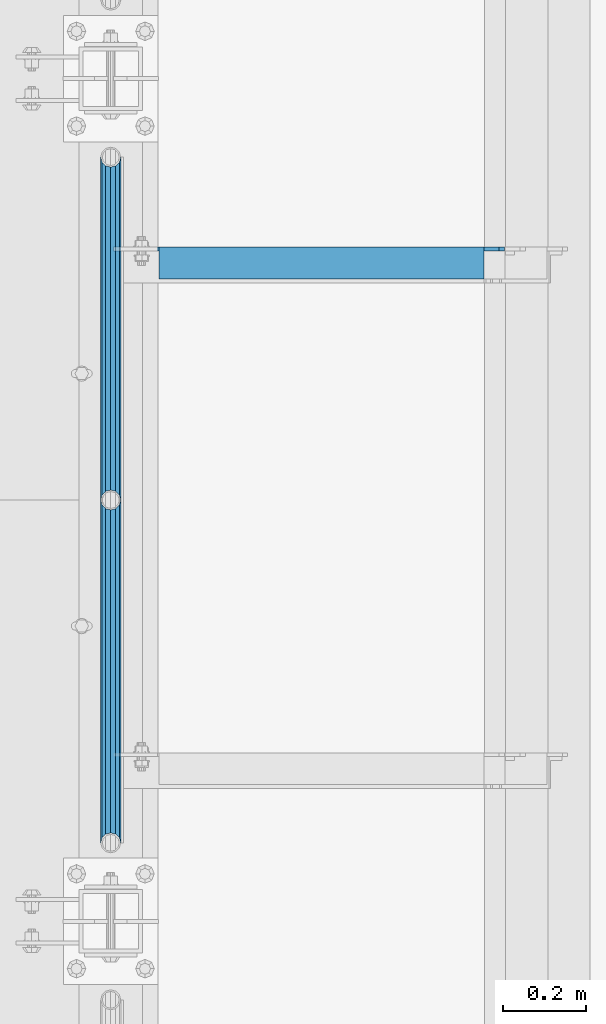
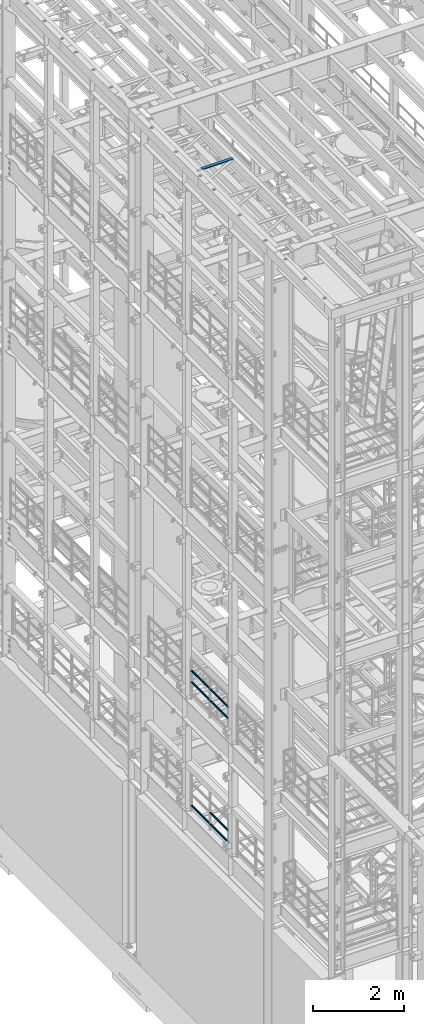
# One storey, part 1228 of 1876: 8 beams, 3 elements without a shape of their own.
"""IFC2X3 building model written with IfcOpenShell, lengths in millimetres."""

from ifc_helpers import new_model, si_unit, frame, origin_with_axes, place, context, subcontext, project, spatial, faceted_brep, material, type_object, element, aggregate, save


model = new_model("IFC2X3")

# Units and contexts
model_context = context("Model", 3, precision=1e-05, world=origin_with_axes())
body_context = subcontext(model_context, "Body", "Model", "MODEL_VIEW")
ifc_project = project(units=[si_unit("LENGTHUNIT", "METRE", prefix="MILLI"), si_unit("AREAUNIT", "SQUARE_METRE"), si_unit("VOLUMEUNIT", "CUBIC_METRE"), si_unit("MASSUNIT", "GRAM", prefix="KILO"), si_unit("TIMEUNIT", "SECOND"), si_unit("PLANEANGLEUNIT", "RADIAN"), si_unit("SOLIDANGLEUNIT", "STERADIAN"), si_unit("THERMODYNAMICTEMPERATUREUNIT", "DEGREE_CELSIUS"), si_unit("LUMINOUSINTENSITYUNIT", "LUMEN")], contexts=[model_context])

# Site, building, storey
site_placement = place(None, origin_with_axes())
site = spatial("IfcSite", under=ifc_project, at=site_placement, CompositionType="ELEMENT")
building_placement = place(site_placement, origin_with_axes())
building = spatial("IfcBuilding", under=site, at=building_placement, Name="Undefined", CompositionType="ELEMENT")
storey_placement = place(building_placement, origin_with_axes())
storey = spatial("IfcBuildingStorey", under=building, at=storey_placement, Name="Undefined", CompositionType="ELEMENT", Elevation=0.0)

# Assembly, beams
assembly_1_placement = place(storey_placement, origin_with_axes())
assembly_1 = element("IfcElementAssembly", 1, at=assembly_1_placement, inside=storey, Name="RAIL", AssemblyPlace="NOTDEFINED", PredefinedType="RIGID_FRAME")
ifc_material_1 = material()
beam_type_1 = type_object("IfcBeamType", Name="PIPE1-1/2SCH40", PredefinedType="NOTDEFINED")
beam_1_placement = place(assembly_1_placement, frame((-1.81898940354586e-12, -2350.77, 8620.125), z_axis=(0.0, 0.0, -1.0), x_axis=(0.0, 1.0, 0.0)))
beam_1 = element("IfcBeam", 2, at=beam_1_placement, type_object=beam_type_1, material=ifc_material_1, Name="RAIL", ObjectType="PIPE1-1/2SCH40", context=body_context, shape_type="Brep", body=[
    faceted_brep([(0.0, 24.1299999999992, 0.0), (12.0650000000064, 20.8971929933177, -12.0649999999987), (12.0650000000064, 20.8971929933177, 12.0649999999987), (12.0650000000064, -20.8971929933177, 12.0649999999987), (12.0650000000064, -20.8971929933177, -12.0649999999987), (0.0, -24.1299999999992, 0.0), (20.8971929933249, -12.0650000000005, 20.8971929933177), (20.8971929933249, -12.0650000000005, 15.8661214311796), (15.2545715621445, -17.7076214311801, 10.2235000000001), (12.5151929933249, -20.4470000000001, 0.0), (15.2545715621445, -17.7076214311801, -10.2235000000001), (20.8971929933249, -12.0650000000005, -15.8661214311796), (20.8971929933249, -12.0650000000005, -20.8971929933177), (24.1300000000063, 0.0, -20.4470000000001), (24.1300000000063, 0.0, -24.130000000001), (21.3906214311868, -10.2235000000001, -17.7076214311819), (21.3906214311868, 10.2235000000001, -17.7076214311819), (20.8971929933249, 12.0650000000005, -15.8661214311796), (20.8971929933249, 12.0650000000005, -20.8971929933177), (15.2545715621445, 17.7076214311801, -10.2235000000001), (12.5151929933249, 20.4470000000001, 0.0), (15.2545715621445, 17.7076214311801, 10.2235000000001), (20.8971929933249, 12.0650000000005, 15.8661214311796), (20.8971929933249, 12.0650000000005, 20.8971929933177), (21.3906214311868, 10.2235000000001, 17.7076214311819), (24.1300000000064, 0.0, 20.4470000000001), (24.1300000000064, 0.0, 24.130000000001), (21.3906214311868, -10.2235000000001, 17.7076214311819), (826.77, 24.1300000000001, 0.0), (814.705, 20.8971929933186, -12.0649999999987), (805.872807006681, 12.0649999999996, -20.8971929933177), (826.77, -24.1300000000001, 0.0), (814.705, -20.8971929933186, -12.0649999999987), (814.705, -20.8971929933186, 12.0649999999987), (805.872807006681, -12.0649999999996, 20.8971929933177), (805.872807006681, -12.0649999999996, -20.8971929933177), (802.640000000001, 0.0, -24.130000000001), (805.379378568819, 10.2235000000001, -17.7076214311819), (802.640000000001, 0.0, -20.4470000000001), (805.872807006683, 12.0649999999996, -15.8661214311796), (805.872807006683, -12.0649999999996, -15.8661214311796), (805.379378568819, -10.2235000000001, -17.7076214311819), (811.515428437862, -17.7076214311801, -10.2235000000001), (814.254807006682, -20.4470000000001, 0.0), (811.515428437862, -17.7076214311801, 10.2235000000001), (805.872807006683, -12.0649999999996, 15.8661214311796), (805.379378568819, -10.2235000000001, 17.7076214311819), (802.640000000001, 0.0, 20.4470000000001), (802.640000000001, 0.0, 24.130000000001), (805.872807006681, 12.0649999999996, 20.8971929933177), (814.705, 20.8971929933186, 12.0649999999987), (805.872807006683, 12.0649999999996, 15.8661214311796), (811.515428437862, 17.7076214311801, 10.2235000000001), (814.254807006682, 20.4470000000001, 0.0), (811.515428437862, 17.7076214311801, -10.2235000000001), (805.379378568819, 10.2235000000001, 17.7076214311819)], [[[0, 1, 2]], [[3, 4, 5]], [[6, 7, 8, 9, 10, 11, 12, 4, 3]], [[13, 14, 12, 11, 15]], [[16, 17, 18, 14, 13]], [[2, 1, 18, 17, 19, 20, 21, 22, 23]], [[23, 22, 24, 25, 26]], [[26, 25, 27, 7, 6]], [[1, 0, 28, 29]], [[18, 1, 29, 30]], [[31, 32, 33]], [[6, 3, 33, 34]], [[3, 5, 31, 33]], [[5, 4, 32, 31]], [[4, 12, 35, 32]], [[12, 14, 36, 35]], [[14, 18, 30, 36]], [[37, 38, 36, 30, 39]], [[40, 35, 36, 38, 41]], [[33, 32, 35, 40, 42, 43, 44, 45, 34]], [[34, 45, 46, 47, 48]], [[26, 6, 34, 48]], [[2, 23, 49, 50]], [[23, 26, 48, 49]], [[0, 2, 50, 28]], [[28, 50, 29]], [[49, 51, 52, 53, 54, 39, 30, 29, 50]], [[48, 47, 55, 51, 49]], [[25, 24, 55, 47]], [[55, 24, 22, 21, 52, 51]], [[21, 20, 53, 52]], [[20, 19, 54, 53]], [[19, 17, 16, 37, 39, 54]], [[16, 13, 38, 37]], [[13, 15, 41, 38]], [[41, 15, 11, 10, 42, 40]], [[10, 9, 43, 42]], [[9, 8, 44, 43]], [[8, 7, 27, 46, 45, 44]], [[27, 25, 47, 46]]]),
])
beam_2_placement = place(assembly_1_placement, frame((-1.81898940354586e-12, -1524.0, 8620.125), z_axis=(0.0, 0.0, -1.0), x_axis=(0.0, 1.0, 0.0)))
beam_2 = element("IfcBeam", 3, at=beam_2_placement, type_object=beam_type_1, material=ifc_material_1, Name="RAIL", ObjectType="PIPE1-1/2SCH40", context=body_context, shape_type="Brep", body=[
    faceted_brep([(0.0, 24.1299999999992, 0.0), (12.0650000000064, 20.8971929933177, -12.0649999999987), (12.0650000000064, 20.8971929933177, 12.0649999999987), (12.0650000000064, -20.8971929933177, 12.0649999999987), (12.0650000000064, -20.8971929933177, -12.0649999999987), (0.0, -24.1299999999992, 0.0), (20.8971929933249, -12.0650000000005, 20.8971929933177), (20.8971929933249, -12.0650000000005, 15.8661214311796), (15.2545715621445, -17.7076214311801, 10.2235000000001), (12.5151929933249, -20.4470000000001, 0.0), (15.2545715621445, -17.7076214311801, -10.2235000000001), (20.8971929933249, -12.0650000000005, -15.8661214311796), (20.8971929933249, -12.0650000000005, -20.8971929933177), (24.1300000000063, 0.0, -20.4470000000001), (24.1300000000063, 0.0, -24.130000000001), (21.3906214311868, -10.2235000000001, -17.7076214311819), (21.3906214311868, 10.2235000000001, -17.7076214311819), (20.8971929933249, 12.0650000000005, -15.8661214311796), (20.8971929933249, 12.0650000000005, -20.8971929933177), (15.2545715621445, 17.7076214311801, -10.2235000000001), (12.5151929933249, 20.4470000000001, 0.0), (15.2545715621445, 17.7076214311801, 10.2235000000001), (20.8971929933249, 12.0650000000005, 15.8661214311796), (20.8971929933249, 12.0650000000005, 20.8971929933177), (21.3906214311868, 10.2235000000001, 17.7076214311819), (24.1300000000064, 0.0, 20.4470000000001), (24.1300000000064, 0.0, 24.130000000001), (21.3906214311868, -10.2235000000001, 17.7076214311819), (826.77, 24.1300000000001, 0.0), (814.705, 20.8971929933186, -12.0649999999987), (805.872807006681, 12.0649999999996, -20.8971929933177), (826.77, -24.1300000000001, 0.0), (814.705, -20.8971929933186, -12.0649999999987), (814.705, -20.8971929933186, 12.0649999999987), (805.872807006681, -12.0649999999996, 20.8971929933177), (805.872807006681, -12.0649999999996, -20.8971929933177), (802.640000000001, 0.0, -24.130000000001), (805.379378568819, 10.2235000000001, -17.7076214311819), (802.640000000001, 0.0, -20.4470000000001), (805.872807006683, 12.0649999999996, -15.8661214311796), (805.872807006683, -12.0649999999996, -15.8661214311796), (805.379378568819, -10.2235000000001, -17.7076214311819), (811.515428437862, -17.7076214311801, -10.2235000000001), (814.254807006682, -20.4470000000001, 0.0), (811.515428437862, -17.7076214311801, 10.2235000000001), (805.872807006683, -12.0649999999996, 15.8661214311796), (805.379378568819, -10.2235000000001, 17.7076214311819), (802.640000000001, 0.0, 20.4470000000001), (802.640000000001, 0.0, 24.130000000001), (805.872807006681, 12.0649999999996, 20.8971929933177), (814.705, 20.8971929933186, 12.0649999999987), (805.872807006683, 12.0649999999996, 15.8661214311796), (811.515428437862, 17.7076214311801, 10.2235000000001), (814.254807006682, 20.4470000000001, 0.0), (811.515428437862, 17.7076214311801, -10.2235000000001), (805.379378568819, 10.2235000000001, 17.7076214311819)], [[[0, 1, 2]], [[3, 4, 5]], [[6, 7, 8, 9, 10, 11, 12, 4, 3]], [[13, 14, 12, 11, 15]], [[16, 17, 18, 14, 13]], [[2, 1, 18, 17, 19, 20, 21, 22, 23]], [[23, 22, 24, 25, 26]], [[26, 25, 27, 7, 6]], [[1, 0, 28, 29]], [[18, 1, 29, 30]], [[31, 32, 33]], [[6, 3, 33, 34]], [[3, 5, 31, 33]], [[5, 4, 32, 31]], [[4, 12, 35, 32]], [[12, 14, 36, 35]], [[14, 18, 30, 36]], [[37, 38, 36, 30, 39]], [[40, 35, 36, 38, 41]], [[33, 32, 35, 40, 42, 43, 44, 45, 34]], [[34, 45, 46, 47, 48]], [[26, 6, 34, 48]], [[2, 23, 49, 50]], [[23, 26, 48, 49]], [[0, 2, 50, 28]], [[28, 50, 29]], [[49, 51, 52, 53, 54, 39, 30, 29, 50]], [[48, 47, 55, 51, 49]], [[25, 24, 55, 47]], [[55, 24, 22, 21, 52, 51]], [[21, 20, 53, 52]], [[20, 19, 54, 53]], [[19, 17, 16, 37, 39, 54]], [[16, 13, 38, 37]], [[13, 15, 41, 38]], [[41, 15, 11, 10, 42, 40]], [[10, 9, 43, 42]], [[9, 8, 44, 43]], [[8, 7, 27, 46, 45, 44]], [[27, 25, 47, 46]]]),
])
beam_3_placement = place(assembly_1_placement, frame((-1.81898940354586e-12, -2350.77, 8924.925), z_axis=(0.0, 0.0, -1.0), x_axis=(0.0, 1.0, 0.0)))
beam_3 = element("IfcBeam", 4, at=beam_3_placement, type_object=beam_type_1, material=ifc_material_1, Name="RAIL", ObjectType="PIPE1-1/2SCH40", context=body_context, shape_type="Brep", body=[
    faceted_brep([(0.0, 24.1299999999992, 0.0), (12.0650000000064, 20.8971929933177, -12.0649999999987), (12.0650000000064, 20.8971929933177, 12.0649999999987), (12.0650000000064, -20.8971929933177, 12.0649999999987), (12.0650000000064, -20.8971929933177, -12.0649999999987), (0.0, -24.1299999999992, 0.0), (20.8971929933249, -12.0650000000005, 20.8971929933177), (20.8971929933249, -12.0650000000005, 15.8661214311796), (15.2545715621445, -17.7076214311801, 10.2235000000001), (12.5151929933249, -20.4470000000001, 0.0), (15.2545715621445, -17.7076214311801, -10.2235000000001), (20.8971929933249, -12.0650000000005, -15.8661214311796), (20.8971929933249, -12.0650000000005, -20.8971929933177), (24.1300000000063, 0.0, -20.4470000000001), (24.1300000000063, 0.0, -24.130000000001), (21.3906214311868, -10.2235000000001, -17.7076214311819), (21.3906214311868, 10.2235000000001, -17.7076214311819), (20.8971929933249, 12.0650000000005, -15.8661214311796), (20.8971929933249, 12.0650000000005, -20.8971929933177), (15.2545715621445, 17.7076214311801, -10.2235000000001), (12.5151929933249, 20.4470000000001, 0.0), (15.2545715621445, 17.7076214311801, 10.2235000000001), (20.8971929933249, 12.0650000000005, 15.8661214311796), (20.8971929933249, 12.0650000000005, 20.8971929933177), (21.3906214311868, 10.2235000000001, 17.7076214311819), (24.1300000000064, 0.0, 20.4470000000001), (24.1300000000064, 0.0, 24.130000000001), (21.3906214311868, -10.2235000000001, 17.7076214311819), (826.77, 24.1300000000001, 0.0), (814.705, 20.8971929933186, -12.0649999999987), (805.872807006681, 12.0649999999996, -20.8971929933177), (826.77, -24.1300000000001, 0.0), (814.705, -20.8971929933186, -12.0649999999987), (814.705, -20.8971929933186, 12.0649999999987), (805.872807006681, -12.0649999999996, 20.8971929933177), (805.872807006681, -12.0649999999996, -20.8971929933177), (802.640000000001, 0.0, -24.130000000001), (805.379378568819, 10.2235000000001, -17.7076214311819), (802.640000000001, 0.0, -20.4470000000001), (805.872807006683, 12.0649999999996, -15.8661214311796), (805.872807006683, -12.0649999999996, -15.8661214311796), (805.379378568819, -10.2235000000001, -17.7076214311819), (811.515428437862, -17.7076214311801, -10.2235000000001), (814.254807006682, -20.4470000000001, 0.0), (811.515428437862, -17.7076214311801, 10.2235000000001), (805.872807006683, -12.0649999999996, 15.8661214311796), (805.379378568819, -10.2235000000001, 17.7076214311819), (802.640000000001, 0.0, 20.4470000000001), (802.640000000001, 0.0, 24.130000000001), (805.872807006681, 12.0649999999996, 20.8971929933177), (814.705, 20.8971929933186, 12.0649999999987), (805.872807006683, 12.0649999999996, 15.8661214311796), (811.515428437862, 17.7076214311801, 10.2235000000001), (814.254807006682, 20.4470000000001, 0.0), (811.515428437862, 17.7076214311801, -10.2235000000001), (805.379378568819, 10.2235000000001, 17.7076214311819)], [[[0, 1, 2]], [[3, 4, 5]], [[6, 7, 8, 9, 10, 11, 12, 4, 3]], [[13, 14, 12, 11, 15]], [[16, 17, 18, 14, 13]], [[2, 1, 18, 17, 19, 20, 21, 22, 23]], [[23, 22, 24, 25, 26]], [[26, 25, 27, 7, 6]], [[1, 0, 28, 29]], [[18, 1, 29, 30]], [[31, 32, 33]], [[6, 3, 33, 34]], [[3, 5, 31, 33]], [[5, 4, 32, 31]], [[4, 12, 35, 32]], [[12, 14, 36, 35]], [[14, 18, 30, 36]], [[37, 38, 36, 30, 39]], [[40, 35, 36, 38, 41]], [[33, 32, 35, 40, 42, 43, 44, 45, 34]], [[34, 45, 46, 47, 48]], [[26, 6, 34, 48]], [[2, 23, 49, 50]], [[23, 26, 48, 49]], [[0, 2, 50, 28]], [[28, 50, 29]], [[49, 51, 52, 53, 54, 39, 30, 29, 50]], [[48, 47, 55, 51, 49]], [[25, 24, 55, 47]], [[55, 24, 22, 21, 52, 51]], [[21, 20, 53, 52]], [[20, 19, 54, 53]], [[19, 17, 16, 37, 39, 54]], [[16, 13, 38, 37]], [[13, 15, 41, 38]], [[41, 15, 11, 10, 42, 40]], [[10, 9, 43, 42]], [[9, 8, 44, 43]], [[8, 7, 27, 46, 45, 44]], [[27, 25, 47, 46]]]),
])
beam_4_placement = place(assembly_1_placement, frame((-1.81898940354586e-12, -1524.0, 8924.925), z_axis=(0.0, 0.0, -1.0), x_axis=(0.0, 1.0, 0.0)))
beam_4 = element("IfcBeam", 5, at=beam_4_placement, type_object=beam_type_1, material=ifc_material_1, Name="RAIL", ObjectType="PIPE1-1/2SCH40", context=body_context, shape_type="Brep", body=[
    faceted_brep([(0.0, 24.1299999999992, 0.0), (12.0650000000064, 20.8971929933177, -12.0649999999987), (12.0650000000064, 20.8971929933177, 12.0649999999987), (12.0650000000064, -20.8971929933177, 12.0649999999987), (12.0650000000064, -20.8971929933177, -12.0649999999987), (0.0, -24.1299999999992, 0.0), (20.8971929933249, -12.0650000000005, 20.8971929933177), (20.8971929933249, -12.0650000000005, 15.8661214311796), (15.2545715621445, -17.7076214311801, 10.2235000000001), (12.5151929933249, -20.4470000000001, 0.0), (15.2545715621445, -17.7076214311801, -10.2235000000001), (20.8971929933249, -12.0650000000005, -15.8661214311796), (20.8971929933249, -12.0650000000005, -20.8971929933177), (24.1300000000063, 0.0, -20.4470000000001), (24.1300000000063, 0.0, -24.130000000001), (21.3906214311868, -10.2235000000001, -17.7076214311819), (21.3906214311868, 10.2235000000001, -17.7076214311819), (20.8971929933249, 12.0650000000005, -15.8661214311796), (20.8971929933249, 12.0650000000005, -20.8971929933177), (15.2545715621445, 17.7076214311801, -10.2235000000001), (12.5151929933249, 20.4470000000001, 0.0), (15.2545715621445, 17.7076214311801, 10.2235000000001), (20.8971929933249, 12.0650000000005, 15.8661214311796), (20.8971929933249, 12.0650000000005, 20.8971929933177), (21.3906214311868, 10.2235000000001, 17.7076214311819), (24.1300000000064, 0.0, 20.4470000000001), (24.1300000000064, 0.0, 24.130000000001), (21.3906214311868, -10.2235000000001, 17.7076214311819), (826.77, 24.1300000000001, 0.0), (814.705, 20.8971929933186, -12.0649999999987), (805.872807006681, 12.0649999999996, -20.8971929933177), (826.77, -24.1300000000001, 0.0), (814.705, -20.8971929933186, -12.0649999999987), (814.705, -20.8971929933186, 12.0649999999987), (805.872807006681, -12.0649999999996, 20.8971929933177), (805.872807006681, -12.0649999999996, -20.8971929933177), (802.640000000001, 0.0, -24.130000000001), (805.379378568819, 10.2235000000001, -17.7076214311819), (802.640000000001, 0.0, -20.4470000000001), (805.872807006683, 12.0649999999996, -15.8661214311796), (805.872807006683, -12.0649999999996, -15.8661214311796), (805.379378568819, -10.2235000000001, -17.7076214311819), (811.515428437862, -17.7076214311801, -10.2235000000001), (814.254807006682, -20.4470000000001, 0.0), (811.515428437862, -17.7076214311801, 10.2235000000001), (805.872807006683, -12.0649999999996, 15.8661214311796), (805.379378568819, -10.2235000000001, 17.7076214311819), (802.640000000001, 0.0, 20.4470000000001), (802.640000000001, 0.0, 24.130000000001), (805.872807006681, 12.0649999999996, 20.8971929933177), (814.705, 20.8971929933186, 12.0649999999987), (805.872807006683, 12.0649999999996, 15.8661214311796), (811.515428437862, 17.7076214311801, 10.2235000000001), (814.254807006682, 20.4470000000001, 0.0), (811.515428437862, 17.7076214311801, -10.2235000000001), (805.379378568819, 10.2235000000001, 17.7076214311819)], [[[0, 1, 2]], [[3, 4, 5]], [[6, 7, 8, 9, 10, 11, 12, 4, 3]], [[13, 14, 12, 11, 15]], [[16, 17, 18, 14, 13]], [[2, 1, 18, 17, 19, 20, 21, 22, 23]], [[23, 22, 24, 25, 26]], [[26, 25, 27, 7, 6]], [[1, 0, 28, 29]], [[18, 1, 29, 30]], [[31, 32, 33]], [[6, 3, 33, 34]], [[3, 5, 31, 33]], [[5, 4, 32, 31]], [[4, 12, 35, 32]], [[12, 14, 36, 35]], [[14, 18, 30, 36]], [[37, 38, 36, 30, 39]], [[40, 35, 36, 38, 41]], [[33, 32, 35, 40, 42, 43, 44, 45, 34]], [[34, 45, 46, 47, 48]], [[26, 6, 34, 48]], [[2, 23, 49, 50]], [[23, 26, 48, 49]], [[0, 2, 50, 28]], [[28, 50, 29]], [[49, 51, 52, 53, 54, 39, 30, 29, 50]], [[48, 47, 55, 51, 49]], [[25, 24, 55, 47]], [[55, 24, 22, 21, 52, 51]], [[21, 20, 53, 52]], [[20, 19, 54, 53]], [[19, 17, 16, 37, 39, 54]], [[16, 13, 38, 37]], [[13, 15, 41, 38]], [[41, 15, 11, 10, 42, 40]], [[10, 9, 43, 42]], [[9, 8, 44, 43]], [[8, 7, 27, 46, 45, 44]], [[27, 25, 47, 46]]]),
])
aggregate(assembly_1, [beam_1, beam_2, beam_3, beam_4])

assembly_2_placement = place(storey_placement, origin_with_axes())
assembly_2 = element("IfcElementAssembly", 6, at=assembly_2_placement, inside=storey, Name="RAIL", AssemblyPlace="NOTDEFINED", PredefinedType="RIGID_FRAME")
beam_5_placement = place(assembly_2_placement, frame((-1.81898940354586e-12, -1524.0, 5292.725), z_axis=(0.0, 0.0, 1.0), x_axis=(0.0, -1.0, 0.0)))
beam_5 = element("IfcBeam", 7, at=beam_5_placement, type_object=beam_type_1, material=ifc_material_1, Name="RAIL", ObjectType="PIPE1-1/2SCH40", context=body_context, shape_type="Brep", body=[
    faceted_brep([(805.872807006681, -12.0649999999996, 20.8971929933177), (805.872807006683, -12.0649999999996, 15.8661214311796), (805.379378568819, -10.2235000000001, 17.7076214311819), (802.640000000001, 0.0, 20.4470000000001), (802.640000000001, 0.0, 24.130000000001), (805.379378568819, 10.2235000000001, 17.7076214311819), (805.872807006683, 12.0649999999996, 15.8661214311796), (805.872807006681, 12.0649999999996, 20.8971929933177), (826.77, 24.1300000000001, 0.0), (814.705, 20.8971929933186, 12.0649999999987), (814.705, 20.8971929933186, -12.0649999999987), (811.515428437862, 17.7076214311801, 10.2235000000001), (814.254807006682, 20.4470000000001, 0.0), (811.515428437862, 17.7076214311801, -10.2235000000001), (805.872807006683, 12.0649999999996, -15.8661214311796), (805.872807006681, 12.0649999999996, -20.8971929933177), (805.379378568819, 10.2235000000001, -17.7076214311819), (802.640000000001, 0.0, -20.4470000000001), (802.640000000001, 0.0, -24.130000000001), (805.872807006683, -12.0649999999996, -15.8661214311796), (805.872807006681, -12.0649999999996, -20.8971929933177), (805.379378568819, -10.2235000000001, -17.7076214311819), (826.77, -24.1300000000001, 0.0), (814.705, -20.8971929933186, -12.0649999999987), (814.705, -20.8971929933186, 12.0649999999987), (811.515428437862, -17.7076214311801, -10.2235000000001), (814.254807006682, -20.4470000000001, 0.0), (811.515428437862, -17.7076214311801, 10.2235000000001), (12.0650000000064, -20.8971929933177, -12.0649999999987), (20.8971929933249, -12.0650000000005, -20.8971929933177), (0.0, 24.1299999999992, 0.0), (12.0650000000064, 20.8971929933177, -12.0649999999987), (12.0650000000064, 20.8971929933177, 12.0649999999987), (20.8971929933249, 12.0650000000005, 20.8971929933177), (24.1300000000064, 0.0, 24.130000000001), (20.8971929933249, 12.0650000000005, -20.8971929933177), (24.1300000000063, 0.0, -24.130000000001), (24.1300000000063, 0.0, -20.4470000000001), (20.8971929933249, -12.0650000000005, -15.8661214311796), (21.3906214311868, -10.2235000000001, -17.7076214311819), (21.3906214311868, 10.2235000000001, -17.7076214311819), (20.8971929933249, 12.0650000000005, -15.8661214311796), (15.2545715621445, 17.7076214311801, -10.2235000000001), (12.5151929933249, 20.4470000000001, 0.0), (15.2545715621445, 17.7076214311801, 10.2235000000001), (20.8971929933249, 12.0650000000005, 15.8661214311796), (21.3906214311868, 10.2235000000001, 17.7076214311819), (24.1300000000064, 0.0, 20.4470000000001), (21.3906214311868, -10.2235000000001, 17.7076214311819), (20.8971929933249, -12.0650000000005, 15.8661214311796), (20.8971929933249, -12.0650000000005, 20.8971929933177), (12.0650000000064, -20.8971929933177, 12.0649999999987), (0.0, -24.1299999999992, 0.0), (15.2545715621445, -17.7076214311801, 10.2235000000001), (12.5151929933249, -20.4470000000001, 0.0), (15.2545715621445, -17.7076214311801, -10.2235000000001)], [[[0, 1, 2, 3, 4]], [[4, 3, 5, 6, 7]], [[8, 9, 10]], [[7, 6, 11, 12, 13, 14, 15, 10, 9]], [[16, 17, 18, 15, 14]], [[19, 20, 18, 17, 21]], [[22, 23, 24]], [[24, 23, 20, 19, 25, 26, 27, 1, 0]], [[28, 29, 20, 23]], [[30, 31, 32]], [[33, 34, 4, 7]], [[32, 33, 7, 9]], [[30, 32, 9, 8]], [[31, 30, 8, 10]], [[35, 31, 10, 15]], [[36, 35, 15, 18]], [[29, 36, 18, 20]], [[37, 36, 29, 38, 39]], [[40, 41, 35, 36, 37]], [[32, 31, 35, 41, 42, 43, 44, 45, 33]], [[33, 45, 46, 47, 34]], [[34, 47, 48, 49, 50]], [[34, 50, 0, 4]], [[50, 51, 24, 0]], [[51, 52, 22, 24]], [[52, 28, 23, 22]], [[51, 28, 52]], [[50, 49, 53, 54, 55, 38, 29, 28, 51]], [[55, 54, 26, 25]], [[21, 39, 38, 55, 25, 19]], [[37, 39, 21, 17]], [[40, 37, 17, 16]], [[42, 41, 40, 16, 14, 13]], [[43, 42, 13, 12]], [[44, 43, 12, 11]], [[5, 46, 45, 44, 11, 6]], [[47, 46, 5, 3]], [[48, 47, 3, 2]], [[53, 49, 48, 2, 1, 27]], [[54, 53, 27, 26]]]),
])
beam_6_placement = place(assembly_2_placement, frame((-1.81898940354586e-12, -697.230000000001, 5292.725), z_axis=(0.0, 0.0, 1.0), x_axis=(0.0, -1.0, 0.0)))
beam_6 = element("IfcBeam", 8, at=beam_6_placement, type_object=beam_type_1, material=ifc_material_1, Name="RAIL", ObjectType="PIPE1-1/2SCH40", context=body_context, shape_type="Brep", body=[
    faceted_brep([(805.872807006681, -12.0649999999996, 20.8971929933177), (805.872807006683, -12.0649999999996, 15.8661214311796), (805.379378568819, -10.2235000000001, 17.7076214311819), (802.640000000001, 0.0, 20.4470000000001), (802.640000000001, 0.0, 24.130000000001), (805.379378568819, 10.2235000000001, 17.7076214311819), (805.872807006683, 12.0649999999996, 15.8661214311796), (805.872807006681, 12.0649999999996, 20.8971929933177), (826.77, 24.1300000000001, 0.0), (814.705, 20.8971929933186, 12.0649999999987), (814.705, 20.8971929933186, -12.0649999999987), (811.515428437862, 17.7076214311801, 10.2235000000001), (814.254807006682, 20.4470000000001, 0.0), (811.515428437862, 17.7076214311801, -10.2235000000001), (805.872807006683, 12.0649999999996, -15.8661214311796), (805.872807006681, 12.0649999999996, -20.8971929933177), (805.379378568819, 10.2235000000001, -17.7076214311819), (802.640000000001, 0.0, -20.4470000000001), (802.640000000001, 0.0, -24.130000000001), (805.872807006683, -12.0649999999996, -15.8661214311796), (805.872807006681, -12.0649999999996, -20.8971929933177), (805.379378568819, -10.2235000000001, -17.7076214311819), (826.77, -24.1300000000001, 0.0), (814.705, -20.8971929933186, -12.0649999999987), (814.705, -20.8971929933186, 12.0649999999987), (811.515428437862, -17.7076214311801, -10.2235000000001), (814.254807006682, -20.4470000000001, 0.0), (811.515428437862, -17.7076214311801, 10.2235000000001), (12.0650000000064, -20.8971929933177, -12.0649999999987), (20.8971929933249, -12.0650000000005, -20.8971929933177), (0.0, 24.1299999999992, 0.0), (12.0650000000064, 20.8971929933177, -12.0649999999987), (12.0650000000064, 20.8971929933177, 12.0649999999987), (20.8971929933249, 12.0650000000005, 20.8971929933177), (24.1300000000064, 0.0, 24.130000000001), (20.8971929933249, 12.0650000000005, -20.8971929933177), (24.1300000000063, 0.0, -24.130000000001), (24.1300000000063, 0.0, -20.4470000000001), (20.8971929933249, -12.0650000000005, -15.8661214311796), (21.3906214311868, -10.2235000000001, -17.7076214311819), (21.3906214311868, 10.2235000000001, -17.7076214311819), (20.8971929933249, 12.0650000000005, -15.8661214311796), (15.2545715621445, 17.7076214311801, -10.2235000000001), (12.5151929933249, 20.4470000000001, 0.0), (15.2545715621445, 17.7076214311801, 10.2235000000001), (20.8971929933249, 12.0650000000005, 15.8661214311796), (21.3906214311868, 10.2235000000001, 17.7076214311819), (24.1300000000064, 0.0, 20.4470000000001), (21.3906214311868, -10.2235000000001, 17.7076214311819), (20.8971929933249, -12.0650000000005, 15.8661214311796), (20.8971929933249, -12.0650000000005, 20.8971929933177), (12.0650000000064, -20.8971929933177, 12.0649999999987), (0.0, -24.1299999999992, 0.0), (15.2545715621445, -17.7076214311801, 10.2235000000001), (12.5151929933249, -20.4470000000001, 0.0), (15.2545715621445, -17.7076214311801, -10.2235000000001)], [[[0, 1, 2, 3, 4]], [[4, 3, 5, 6, 7]], [[8, 9, 10]], [[7, 6, 11, 12, 13, 14, 15, 10, 9]], [[16, 17, 18, 15, 14]], [[19, 20, 18, 17, 21]], [[22, 23, 24]], [[24, 23, 20, 19, 25, 26, 27, 1, 0]], [[28, 29, 20, 23]], [[30, 31, 32]], [[33, 34, 4, 7]], [[32, 33, 7, 9]], [[30, 32, 9, 8]], [[31, 30, 8, 10]], [[35, 31, 10, 15]], [[36, 35, 15, 18]], [[29, 36, 18, 20]], [[37, 36, 29, 38, 39]], [[40, 41, 35, 36, 37]], [[32, 31, 35, 41, 42, 43, 44, 45, 33]], [[33, 45, 46, 47, 34]], [[34, 47, 48, 49, 50]], [[34, 50, 0, 4]], [[50, 51, 24, 0]], [[51, 52, 22, 24]], [[52, 28, 23, 22]], [[51, 28, 52]], [[50, 49, 53, 54, 55, 38, 29, 28, 51]], [[55, 54, 26, 25]], [[21, 39, 38, 55, 25, 19]], [[37, 39, 21, 17]], [[40, 37, 17, 16]], [[42, 41, 40, 16, 14, 13]], [[43, 42, 13, 12]], [[44, 43, 12, 11]], [[5, 46, 45, 44, 11, 6]], [[47, 46, 5, 3]], [[48, 47, 3, 2]], [[53, 49, 48, 2, 1, 27]], [[54, 53, 27, 26]]]),
])
beam_7_placement = place(assembly_2_placement, frame((-1.81898940354586e-12, -2350.77, 5597.525), z_axis=(0.0, 0.0, -1.0), x_axis=(0.0, 1.0, 0.0)))
beam_7 = element("IfcBeam", 9, at=beam_7_placement, type_object=beam_type_1, material=ifc_material_1, Name="RAIL", ObjectType="PIPE1-1/2SCH40", context=body_context, shape_type="Brep", body=[
    faceted_brep([(0.0, 24.1299999999992, 0.0), (12.0650000000064, 20.8971929933177, -12.0649999999987), (12.0650000000064, 20.8971929933177, 12.0649999999987), (12.0650000000064, -20.8971929933177, 12.0649999999987), (12.0650000000064, -20.8971929933177, -12.0649999999987), (0.0, -24.1299999999992, 0.0), (20.8971929933249, -12.0650000000005, 20.8971929933177), (20.8971929933249, -12.0650000000005, 15.8661214311796), (15.2545715621445, -17.7076214311801, 10.2235000000001), (12.5151929933249, -20.4470000000001, 0.0), (15.2545715621445, -17.7076214311801, -10.2235000000001), (20.8971929933249, -12.0650000000005, -15.8661214311796), (20.8971929933249, -12.0650000000005, -20.8971929933177), (24.1300000000063, 0.0, -20.4470000000001), (24.1300000000063, 0.0, -24.130000000001), (21.3906214311868, -10.2235000000001, -17.7076214311819), (21.3906214311868, 10.2235000000001, -17.7076214311819), (20.8971929933249, 12.0650000000005, -15.8661214311796), (20.8971929933249, 12.0650000000005, -20.8971929933177), (15.2545715621445, 17.7076214311801, -10.2235000000001), (12.5151929933249, 20.4470000000001, 0.0), (15.2545715621445, 17.7076214311801, 10.2235000000001), (20.8971929933249, 12.0650000000005, 15.8661214311796), (20.8971929933249, 12.0650000000005, 20.8971929933177), (21.3906214311868, 10.2235000000001, 17.7076214311819), (24.1300000000064, 0.0, 20.4470000000001), (24.1300000000064, 0.0, 24.130000000001), (21.3906214311868, -10.2235000000001, 17.7076214311819), (826.77, 24.1300000000001, 0.0), (814.705, 20.8971929933186, -12.0649999999987), (805.872807006681, 12.0649999999996, -20.8971929933177), (826.77, -24.1300000000001, 0.0), (814.705, -20.8971929933186, -12.0649999999987), (814.705, -20.8971929933186, 12.0649999999987), (805.872807006681, -12.0649999999996, 20.8971929933177), (805.872807006681, -12.0649999999996, -20.8971929933177), (802.640000000001, 0.0, -24.130000000001), (805.379378568819, 10.2235000000001, -17.7076214311819), (802.640000000001, 0.0, -20.4470000000001), (805.872807006683, 12.0649999999996, -15.8661214311796), (805.872807006683, -12.0649999999996, -15.8661214311796), (805.379378568819, -10.2235000000001, -17.7076214311819), (811.515428437862, -17.7076214311801, -10.2235000000001), (814.254807006682, -20.4470000000001, 0.0), (811.515428437862, -17.7076214311801, 10.2235000000001), (805.872807006683, -12.0649999999996, 15.8661214311796), (805.379378568819, -10.2235000000001, 17.7076214311819), (802.640000000001, 0.0, 20.4470000000001), (802.640000000001, 0.0, 24.130000000001), (805.872807006681, 12.0649999999996, 20.8971929933177), (814.705, 20.8971929933186, 12.0649999999987), (805.872807006683, 12.0649999999996, 15.8661214311796), (811.515428437862, 17.7076214311801, 10.2235000000001), (814.254807006682, 20.4470000000001, 0.0), (811.515428437862, 17.7076214311801, -10.2235000000001), (805.379378568819, 10.2235000000001, 17.7076214311819)], [[[0, 1, 2]], [[3, 4, 5]], [[6, 7, 8, 9, 10, 11, 12, 4, 3]], [[13, 14, 12, 11, 15]], [[16, 17, 18, 14, 13]], [[2, 1, 18, 17, 19, 20, 21, 22, 23]], [[23, 22, 24, 25, 26]], [[26, 25, 27, 7, 6]], [[1, 0, 28, 29]], [[18, 1, 29, 30]], [[31, 32, 33]], [[6, 3, 33, 34]], [[3, 5, 31, 33]], [[5, 4, 32, 31]], [[4, 12, 35, 32]], [[12, 14, 36, 35]], [[14, 18, 30, 36]], [[37, 38, 36, 30, 39]], [[40, 35, 36, 38, 41]], [[33, 32, 35, 40, 42, 43, 44, 45, 34]], [[34, 45, 46, 47, 48]], [[26, 6, 34, 48]], [[2, 23, 49, 50]], [[23, 26, 48, 49]], [[0, 2, 50, 28]], [[28, 50, 29]], [[49, 51, 52, 53, 54, 39, 30, 29, 50]], [[48, 47, 55, 51, 49]], [[25, 24, 55, 47]], [[55, 24, 22, 21, 52, 51]], [[21, 20, 53, 52]], [[20, 19, 54, 53]], [[19, 17, 16, 37, 39, 54]], [[16, 13, 38, 37]], [[13, 15, 41, 38]], [[41, 15, 11, 10, 42, 40]], [[10, 9, 43, 42]], [[9, 8, 44, 43]], [[8, 7, 27, 46, 45, 44]], [[27, 25, 47, 46]]]),
])
aggregate(assembly_2, [beam_5, beam_6, beam_7])

# Assembly, beam
assembly_3_placement = place(storey_placement, origin_with_axes())
assembly_3 = element("IfcElementAssembly", 10, at=assembly_3_placement, inside=storey, Name="ANGLE", AssemblyPlace="NOTDEFINED", PredefinedType="RIGID_FRAME")
ifc_material_2 = material(Name="STEEL/A36")
beam_type_2 = type_object("IfcBeamType", Name="L3X3X3/8", PredefinedType="NOTDEFINED")
beam_8_placement = place(assembly_3_placement, frame((4.51516825708356e-09, -952.5, 22517.1), z_axis=(0.0, -1.0, 0.0), x_axis=(1.0, 0.0, 0.0)))
beam_8 = element("IfcBeam", 11, at=beam_8_placement, type_object=beam_type_2, material=ifc_material_2, Name="ANGLE", ObjectType="L3X3X3/8", context=body_context, shape_type="Brep", body=[
    faceted_brep([(115.886999817316, 28.5750000000007, 38.0999999999999), (115.886999817316, 38.0999999999985, 38.0999999999999), (115.886998826692, 38.0999999999985, -38.0999999999999), (115.88699882669, 12.699999237062, -38.0999999999999), (115.886998950515, 12.699999237062, -28.5749999999998), (115.88699895052, 28.5750000000007, -28.5749999999998), (38.8937432114558, 12.699999237062, -38.0999999999999), (38.8937433352807, 12.699999237062, -28.5749999999998), (7.14374321145577, -19.050000762938, -38.0999999999999), (7.14374333528067, -19.050000762938, -28.5749999999998), (7.1437499954859, -38.0999999999985, -38.0999999999999), (7.1437499954859, -38.0999999999985, -28.5749999999998), (949.325002419604, 15.8750003814712, -28.5749999999998), (936.625002610339, 28.5750000000007, -28.5749999999998), (900.113000619098, 28.5750000000007, -28.5749999999998), (949.324999995485, -38.0999999999985, -28.5749999999998), (949.325002419604, 3.17500152588036, -28.5749999999998), (900.11300241932, 28.5750000000007, 38.0999999999999), (900.1130024193, 38.0999999999985, 38.0999999999999), (900.113000361957, 38.0999999999985, -38.0999999999999), (900.113000361924, 28.5750001907363, -38.0999999999999), (936.625002353164, 28.5750001907363, -38.0999999999999), (949.325002162429, 15.8750003814712, -38.0999999999999), (949.325002162429, 3.17500152588036, -38.0999999999999), (949.324999995485, -38.0999999999985, -38.0999999999999)], [[[0, 1, 2, 3, 4, 5]], [[4, 3, 6, 7]], [[7, 6, 8, 9]], [[8, 10, 11, 9]], [[12, 13, 14, 5, 4, 7, 9, 11, 15, 16]], [[0, 5, 14, 17]], [[1, 0, 17, 18]], [[2, 1, 18, 19]], [[17, 14, 20, 19, 18]], [[13, 21, 20, 14]], [[12, 22, 21, 13]], [[16, 23, 22, 12]], [[10, 8, 6, 3, 2, 19, 20, 21, 22, 23, 24]], [[11, 10, 24, 15]], [[23, 16, 15, 24]]]),
])
aggregate(assembly_3, [beam_8])

save(model, "model.ifc")
